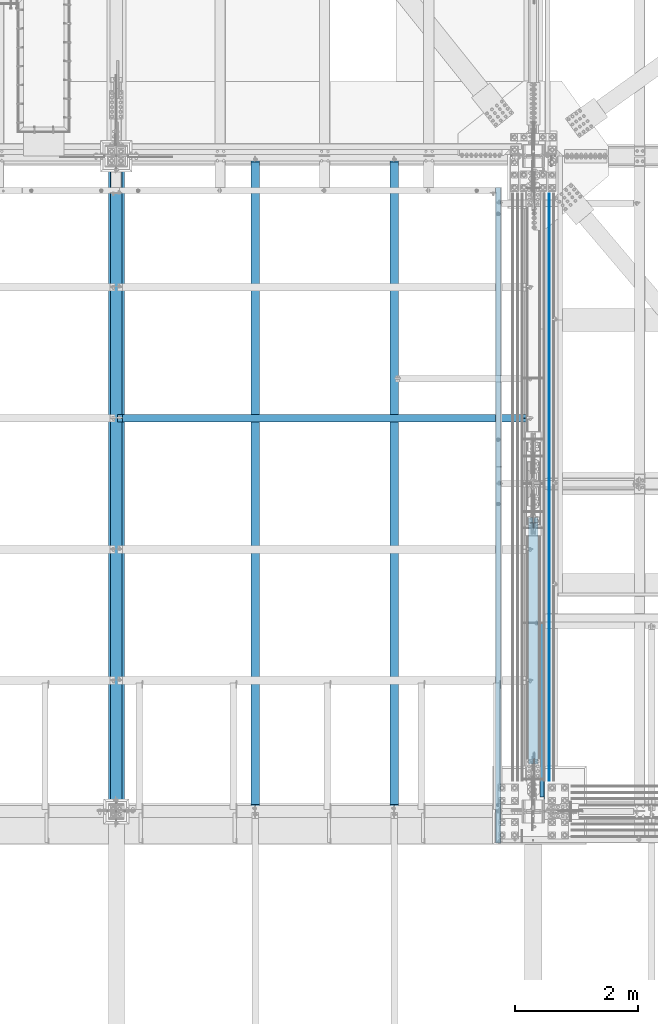
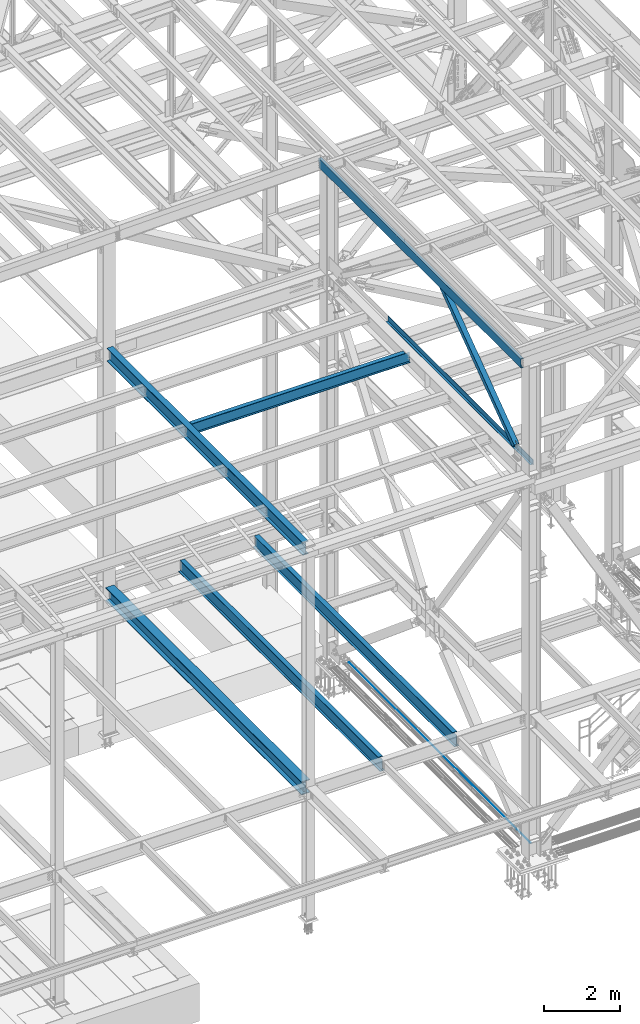
# One storey, part 1795 of 3843: 8 beams, 1 member, 9 elements without a shape of their own.
"""IFC2X3 building model written with IfcOpenShell, lengths in millimetres."""

from ifc_helpers import new_model, si_unit, frame, origin_with_axes, place, context, subcontext, project, spatial, faceted_brep, material, type_object, element, aggregate, save


model = new_model("IFC2X3")

# Units and contexts
model_context = context("Model", 3, precision=1e-05, world=origin_with_axes())
body_context = subcontext(model_context, "Body", "Model", "MODEL_VIEW")
ifc_project = project(units=[si_unit("LENGTHUNIT", "METRE", prefix="MILLI"), si_unit("AREAUNIT", "SQUARE_METRE"), si_unit("VOLUMEUNIT", "CUBIC_METRE"), si_unit("MASSUNIT", "GRAM", prefix="KILO"), si_unit("TIMEUNIT", "SECOND"), si_unit("PLANEANGLEUNIT", "RADIAN"), si_unit("SOLIDANGLEUNIT", "STERADIAN"), si_unit("THERMODYNAMICTEMPERATUREUNIT", "DEGREE_CELSIUS"), si_unit("LUMINOUSINTENSITYUNIT", "LUMEN")], contexts=[model_context])

# Site, building, storey
site_placement = place(None, origin_with_axes())
site = spatial("IfcSite", under=ifc_project, at=site_placement, CompositionType="ELEMENT")
building_placement = place(site_placement, origin_with_axes())
building = spatial("IfcBuilding", under=site, at=building_placement, Name="Undefined", CompositionType="ELEMENT")
storey_placement = place(building_placement, origin_with_axes())
storey = spatial("IfcBuildingStorey", under=building, at=storey_placement, Name="Undefined", CompositionType="ELEMENT", Elevation=0.0)

# Assembly, beam
assembly_1_placement = place(storey_placement, origin_with_axes())
assembly_1 = element("IfcElementAssembly", 1, at=assembly_1_placement, inside=storey, Name="CHANNEL", AssemblyPlace="NOTDEFINED", PredefinedType="RIGID_FRAME")
ifc_material_1 = material(Name="STEEL/A572-50")
beam_type_1 = type_object("IfcBeamType", Name="C12X20.7", PredefinedType="NOTDEFINED")
beam_1_placement = place(assembly_1_placement, frame((76444.5150555766, 14490.7, 46420.6519803864), z_axis=(-0.0211520980073474, 0.0, 0.999776269347241), x_axis=(0.0, 1.0, 0.0)))
beam_1 = element("IfcBeam", 2, at=beam_1_placement, type_object=beam_type_1, material=ifc_material_1, Name="CHANNEL", ObjectType="C12X20.7", context=body_context, shape_type="Brep", body=[
    faceted_brep([(0.0, 38.0999999999985, -152.400000000001), (0.0, 38.0999999999985, 152.400000000001), (10617.1999999989, 38.1000000003551, 152.399999999732), (10617.1999999989, 38.1000000000495, -152.399999999776), (0.0, -38.0999999999985, 152.400000000001), (10617.1999999989, -38.1000000000786, 152.39999999979), (0.0, -38.0999999999985, 146.047460000002), (10617.1999999989, -38.1000000000786, 146.047459999805), (0.0, 30.1624999999985, 134.6749275), (10617.1999999989, 30.1625000002969, 134.674927499764), (0.0, 30.1624999999985, -134.6749275), (10617.1999999989, 30.1625000000058, -134.6749274998), (0.0, -38.0999999999985, -146.047460000002), (10617.1999999989, -38.1000000003696, -146.047459999725), (0.0, -38.0999999999985, -152.400000000001), (10617.1999999989, -38.1000000003842, -152.399999999718)], [[[0, 1, 2, 3]], [[1, 4, 5, 2]], [[4, 6, 7, 5]], [[6, 8, 9, 7]], [[8, 10, 11, 9]], [[10, 12, 13, 11]], [[12, 14, 15, 13]], [[14, 0, 3, 15]], [[5, 7, 9, 11, 13, 15, 3, 2]], [[14, 12, 10, 8, 6, 4, 1, 0]]]),
])
aggregate(assembly_1, [beam_1])

assembly_2_placement = place(storey_placement, origin_with_axes())
assembly_2 = element("IfcElementAssembly", 3, at=assembly_2_placement, inside=storey, Name="REBAR", AssemblyPlace="NOTDEFINED", PredefinedType="RIGID_FRAME")
ifc_material_2 = material(Name="STEEL/A706-60")
beam_type_2 = type_object("IfcBeamType", Name="#10 REBAR", PredefinedType="NOTDEFINED")
beam_2_placement = place(assembly_2_placement, frame((77266.8, 25006.3, 30157.7375), z_axis=(0.0, 0.0, 1.0), x_axis=(0.0, -1.0, 0.0)))
beam_2 = element("IfcBeam", 4, at=beam_2_placement, type_object=beam_type_2, material=ifc_material_2, Name="REBAR", ObjectType="#10 REBAR", context=body_context, shape_type="Brep", body=[
    faceted_brep([(0.0, -7.9375, 0.0), (0.0, -5.61266007566883, -5.61266007566883), (9512.38738280515, -5.61266007566883, -5.61266007566883), (9512.38738280515, -7.9375, 0.0), (0.0, 0.0, -7.9375), (9512.38738280515, 0.0, -7.9375), (0.0, 5.61266007566883, -5.61266007566883), (9512.38738280515, 5.61266007566883, -5.61266007566883), (0.0, 7.9375, 0.0), (9512.38738280515, 7.9375, 0.0), (0.0, 5.61266007566883, 5.61266007566883), (9512.38738280515, 5.61266007566883, 5.61266007566883), (0.0, 0.0, 7.9375), (9512.38738280515, 0.0, 7.9375), (0.0, -5.61266007566883, 5.61266007566883), (9512.38738280515, -5.61266007566883, 5.61266007566883)], [[[0, 1, 2, 3]], [[1, 4, 5, 2]], [[4, 6, 7, 5]], [[6, 8, 9, 7]], [[8, 10, 11, 9]], [[10, 12, 13, 11]], [[12, 14, 15, 13]], [[14, 0, 3, 15]], [[5, 7, 9, 11, 13, 15, 3, 2]], [[14, 12, 10, 8, 6, 4, 1, 0]]]),
])
aggregate(assembly_2, [beam_2])

assembly_3_placement = place(storey_placement, origin_with_axes())
assembly_3 = element("IfcElementAssembly", 5, at=assembly_3_placement, inside=storey, Name="BENT_PLATE", AssemblyPlace="NOTDEFINED", PredefinedType="RIGID_FRAME")
ifc_material_3 = material(Name="STEEL/A36")
beam_type_3 = type_object("IfcBeamType", PredefinedType="NOTDEFINED")
beam_3_placement = place(assembly_3_placement, frame((77117.5749999987, 19003.9625, 42471.975), z_axis=(0.0, -1.0, 0.0), x_axis=(1.0, 0.0, 0.0)))
beam_3 = element("IfcBeam", 6, at=beam_3_placement, type_object=beam_type_3, material=ifc_material_3, Name="BENT_PLATE", context=body_context, shape_type="Brep", body=[
    faceted_brep([(9.52499997243285, -3.17500000000291, 3153.56874999937), (9.52499997243285, 3.17499999999563, 3153.56874999937), (0.0, 3.17500000000291, 3153.56875000306), (0.0, -3.17500000000291, 3153.56875000306), (9.5249999724183, -3.17500000000291, 3471.06874999936), (9.5249999724183, 3.17499999999563, 3471.06874999936), (0.0, -3.17500000000291, 3471.06874999937), (0.0, 3.17500000000291, 3471.06874999937), (73.0250000012456, -3.17500000001746, 3810.0), (73.0250000012456, -3.17500000001746, -3810.0), (73.0250000012456, 161.924999998715, -3810.0), (73.0250000012456, 161.924999998715, 3810.0), (66.6750000011525, -3.17500000001746, 3772.68489935418), (66.6750000012398, 3.17499999998836, 3772.68489935418), (0.0, 3.17500000000291, 3772.68489935418), (0.0, -3.17500000000291, 3772.68489935418), (66.675000001138, -3.17500000001746, 3810.0), (66.6750000012398, 3.17499999998836, 3810.0), (66.6750000012398, 161.924999998715, 3810.0), (66.6750000012398, 101.124999999993, 3810.0), (66.6750000012398, 3.17499999998836, -3810.0), (66.6750000012398, 161.924999998715, -3810.0), (0.0, -3.17500000000291, -3810.0), (0.0, 3.17500000000291, -3810.0)], [[[0, 1, 2, 3]], [[4, 5, 1, 0]], [[6, 7, 5, 4]], [[8, 9, 10, 11]], [[12, 13, 14, 15]], [[16, 17, 13, 12]], [[8, 11, 18, 19, 17, 16]], [[20, 13, 17, 19, 18, 21]], [[11, 10, 21, 18]], [[9, 22, 23, 20, 21, 10]], [[23, 22, 3, 2]], [[14, 13, 20, 23, 2, 1, 5, 7]], [[15, 14, 7, 6]], [[3, 22, 9, 8, 16, 12, 15, 6, 4, 0]]]),
])
aggregate(assembly_3, [beam_3])

# Assembly, member
assembly_4_placement = place(storey_placement, origin_with_axes())
assembly_4 = element("IfcElementAssembly", 7, at=assembly_4_placement, inside=storey, AssemblyPlace="NOTDEFINED", PredefinedType="RIGID_FRAME")
ifc_material_4 = material()
member_type = type_object("IfcMemberType", Name="HSS6X6X3/8", PredefinedType="NOTDEFINED")
member_placement = place(assembly_4_placement, frame((77012.8, 14998.7, 42197.3375), z_axis=(1.0, 0.0, 0.0), x_axis=(0.0, 0.80816825191759, 0.588951675939942)))
member = element("IfcMember", 8, at=member_placement, type_object=member_type, material=ifc_material_4, ObjectType="HSS6X6X3/8", context=body_context, shape_type="Brep", body=[
    faceted_brep([(1006.47933077956, -76.1999999982509, 20.6374999999971), (1006.47933077959, -66.6749999982421, 20.6374999999971), (1106.49183077885, -66.6749999980639, 20.6374999999971), (1106.49183077881, -76.1999999980653, 20.6374999999971), (1109.52938052324, -66.6749999980566, 20.0332937893108), (1109.52938052321, -76.1999999980653, 20.0332937893108), (1112.10449085452, -66.6749999980566, 18.3126600756659), (1112.10449085449, -76.1999999980653, 18.3126600756659), (1113.82512456816, -66.674999998053, 15.7375497444009), (1113.82512456813, -76.199999998058, 15.7375497444009), (1106.49183077881, -76.1999999980653, 4.76249999999709), (1106.49183077885, -66.6749999980639, 4.76249999999709), (1006.47933077959, -66.6749999982421, 4.76249999999709), (1006.47933077956, -76.1999999982509, 4.76249999999709), (1109.52938052321, -76.1999999980653, 5.36670621068333), (1109.52938052324, -66.6749999980566, 5.36670621068333), (1112.10449085449, -76.1999999980653, 7.08733992432826), (1112.10449085452, -66.6749999980566, 7.08733992432826), (1113.82512456813, -76.199999998058, 9.66245025559328), (1113.82512456816, -66.674999998053, 9.66245025559328), (1114.42933077882, -76.199999998058, 12.6999999999971), (1114.42933077885, -66.6749999980493, 12.6999999999971), (1006.47933077993, 66.6750000018656, 20.6374999999971), (1006.47933077996, 76.2000000018743, 20.6374999999971), (1106.49183077931, 76.2000000020525, 20.6374999999971), (1106.49183077928, 66.6750000020511, 20.6374999999971), (1109.52938052371, 76.2000000020562, 20.0332937893108), (1109.52938052368, 66.6750000020511, 20.0332937893108), (1112.10449085499, 76.2000000020635, 18.3126600756659), (1112.10449085495, 66.6750000020584, 18.3126600756659), (1113.82512456863, 76.2000000020671, 15.7375497444009), (1113.8251245686, 66.6750000020584, 15.7375497444009), (1106.49183077928, 66.6750000020511, 4.76249999999709), (1106.49183077931, 76.2000000020525, 4.76249999999709), (1006.47933077996, 76.2000000018743, 4.76249999999709), (1006.47933077993, 66.6750000018656, 4.76249999999709), (1109.52938052368, 66.6750000020511, 5.36670621068333), (1109.52938052371, 76.2000000020562, 5.36670621068333), (1112.10449085495, 66.6750000020584, 7.08733992432826), (1112.10449085499, 76.2000000020635, 7.08733992432826), (1113.8251245686, 66.6750000020584, 9.66245025559328), (1113.82512456863, 76.2000000020671, 9.66245025559328), (1114.42933077929, 66.6750000020656, 12.6999999999971), (1114.42933077933, 76.2000000020671, 12.6999999999971), (1006.47933077959, -66.6749999982421, 66.6750000000029), (1006.47933077993, 66.6750000018656, 66.6750000000029), (5842.45196320163, 66.675000010564, 66.6750000000029), (5842.45196320129, -66.6749999895401, 66.6750000000029), (1006.47933077996, 76.2000000018743, 76.1999999999971), (5842.45196320165, 76.2000000105763, 76.1999999999971), (5842.45196320165, 76.2000000105763, 7.9374999889551), (5742.43946319877, 76.2000000103981, 7.9374999889551), (5739.40191345436, 76.2000000103908, 7.33329377826885), (5736.82680312308, 76.2000000103835, 5.61266006462392), (5735.10616940944, 76.2000000103835, 3.0375497333589), (5734.50196319875, 76.2000000103799, -1.10449036583304e-08), (5735.10616940944, 76.2000000103835, -3.03754975544871), (5736.82680312308, 76.2000000103835, -5.61266008671373), (5739.40191345436, 76.2000000103908, -7.33329380035866), (5742.43946319877, 76.2000000103981, -7.9375000110449), (5842.45196320165, 76.2000000105763, -7.9375000110449), (5842.45196320165, 76.2000000105763, -76.1999999999971), (1006.47933077996, 76.2000000018743, -76.1999999999971), (5842.45196320163, 66.675000010564, 7.9374999889551), (5742.43946319875, 66.6750000103893, 7.9374999889551), (5739.40191345434, 66.6750000103821, 7.33329377826885), (5736.82680312307, 66.6750000103784, 5.61266006462392), (5735.10616940942, 66.6750000103711, 3.0375497333589), (5734.50196319873, 66.6750000103748, -1.10449036583304e-08), (5735.10616940942, 66.6750000103711, -3.03754975544871), (5736.82680312307, 66.6750000103784, -5.61266008671373), (5739.40191345434, 66.6750000103821, -7.33329380035866), (5742.43946319875, 66.6750000103893, -7.9375000110449), (5842.45196320163, 66.675000010564, -7.9375000110449), (1006.47933077993, 66.6750000018656, -66.6750000000029), (1006.47933077959, -66.6749999982421, -66.6750000000029), (5842.45196320129, -66.6749999895401, -66.6750000000029), (5842.45196320163, 66.675000010564, -66.6750000000029), (5739.40191345409, -76.1999999897307, 7.33329377826885), (5739.40191345411, -66.6749999897183, 7.33329377826885), (5742.43946319851, -66.6749999897183, 7.9374999889551), (5742.43946319849, -76.1999999897344, 7.9374999889551), (5736.82680312281, -76.199999989738, 5.61266006462392), (5736.82680312283, -66.6749999897256, 5.61266006462392), (5735.10616940917, -76.199999989738, 3.0375497333589), (5735.10616940918, -66.6749999897329, 3.0375497333589), (5734.50196319847, -76.1999999897416, -1.10449036583304e-08), (5734.50196319848, -66.6749999897293, -1.10449036583304e-08), (5735.10616940917, -76.199999989738, -3.03754975544871), (5735.10616940918, -66.6749999897329, -3.03754975544871), (5736.82680312281, -76.199999989738, -5.61266008671373), (5736.82680312283, -66.6749999897256, -5.61266008671373), (5739.40191345409, -76.1999999897307, -7.33329380035866), (5739.40191345411, -66.6749999897183, -7.33329380035866), (5742.43946319849, -76.1999999897344, -7.9375000110449), (5742.43946319851, -66.6749999897183, -7.9375000110449), (5842.45196320127, -76.1999999895488, -7.9375000110449), (5842.45196320129, -66.6749999895401, -7.9375000110449), (5842.45196320127, -76.1999999895488, -76.1999999999971), (1006.47933077956, -76.1999999982509, -76.1999999999971), (5842.45196320129, -66.6749999895401, 7.9374999889551), (5842.45196320127, -76.1999999895488, 7.9374999889551), (5842.45196320127, -76.1999999895488, 76.1999999999971), (1006.47933077956, -76.1999999982509, 76.1999999999971)], [[[0, 1, 2, 3]], [[3, 2, 4, 5]], [[5, 4, 6, 7]], [[7, 6, 8, 9]], [[10, 11, 12, 13]], [[14, 15, 11, 10]], [[16, 17, 15, 14]], [[18, 19, 17, 16]], [[20, 21, 19, 18]], [[9, 8, 21, 20]], [[22, 23, 24, 25]], [[25, 24, 26, 27]], [[27, 26, 28, 29]], [[29, 28, 30, 31]], [[32, 33, 34, 35]], [[36, 37, 33, 32]], [[38, 39, 37, 36]], [[40, 41, 39, 38]], [[42, 43, 41, 40]], [[31, 30, 43, 42]], [[44, 45, 46, 47]], [[28, 26, 24, 23, 48, 49, 50, 51, 52, 53, 54, 55, 56, 57, 58, 59, 60, 61, 62, 34, 33, 37, 39, 41, 43, 30]], [[63, 64, 51, 50]], [[65, 52, 51, 64]], [[66, 53, 52, 65]], [[67, 54, 53, 66]], [[68, 55, 54, 67]], [[69, 56, 55, 68]], [[70, 57, 56, 69]], [[71, 58, 57, 70]], [[72, 59, 58, 71]], [[73, 60, 59, 72]], [[74, 75, 76, 77]], [[78, 79, 80, 81]], [[82, 83, 79, 78]], [[84, 85, 83, 82]], [[86, 87, 85, 84]], [[88, 89, 87, 86]], [[90, 91, 89, 88]], [[92, 93, 91, 90]], [[94, 95, 93, 92]], [[96, 97, 95, 94]], [[98, 61, 60, 73, 77, 76, 97, 96]], [[99, 62, 61, 98]], [[75, 74, 35, 34, 62, 99, 13, 12]], [[6, 4, 2, 1, 44, 47, 100, 80, 79, 83, 85, 87, 89, 91, 93, 95, 97, 76, 75, 12, 11, 15, 17, 19, 21, 8]], [[101, 81, 80, 100]], [[47, 46, 63, 50, 49, 102, 101, 100]], [[48, 103, 102, 49]], [[16, 14, 10, 13, 99, 98, 96, 94, 92, 90, 88, 86, 84, 82, 78, 81, 101, 102, 103, 0, 3, 5, 7, 9, 20, 18]], [[103, 48, 23, 22, 45, 44, 1, 0]], [[38, 36, 32, 35, 74, 77, 73, 72, 71, 70, 69, 68, 67, 66, 65, 64, 63, 46, 45, 22, 25, 27, 29, 31, 42, 40]]]),
])
aggregate(assembly_4, [member])

# Assembly, beam
assembly_5_placement = place(storey_placement, origin_with_axes())
assembly_5 = element("IfcElementAssembly", 9, at=assembly_5_placement, inside=storey, Name="BEAM", AssemblyPlace="NOTDEFINED", PredefinedType="RIGID_FRAME")
ifc_material_5 = material(Name="STEEL/A992")
beam_type_4 = type_object("IfcBeamType", Name="W14X26", PredefinedType="NOTDEFINED")
beam_4_placement = place(assembly_5_placement, frame((70256.4, 21369.02, 42292.5875), z_axis=(0.0, 0.0, 1.0), x_axis=(1.0, 0.0, 0.0)))
beam_4 = element("IfcBeam", 10, at=beam_4_placement, type_object=beam_type_4, material=ifc_material_5, Name="BEAM", ObjectType="W14X26", context=body_context, shape_type="Brep", body=[
    faceted_brep([(6588.12499999999, -63.5, 176.212500000001), (6588.12499999999, -63.5, 165.099999999999), (6588.12499999999, -3.17499999999927, 165.099999999999), (6588.12499999999, -3.17499999999927, 136.524999809262), (6588.12499999999, 3.17499999999927, 136.524999809262), (6588.12499999999, 3.17499999999927, 165.099999999999), (6588.12499999999, 63.5, 165.099999999999), (6588.12499999999, 63.5, 176.212500000001), (6589.09172992257, -3.17499999999927, 131.664920291216), (6589.09172992257, 3.17499999999927, 131.664920291216), (6591.84474382305, -3.17499999999927, 127.544743823062), (6591.84474382305, 3.17499999999927, 127.544743823062), (6595.96492029121, -3.17499999999927, 124.791729922588), (6595.96492029121, 3.17499999999927, 124.791729922588), (6600.82499980925, -3.17499999999927, 123.824999999997), (6600.82499980925, 3.17499999999927, 123.824999999997), (6737.34999999999, -3.17499999999927, 123.824999999997), (6737.34999999999, 3.17499999999927, 123.824999999997), (103.18750152587, -63.5, 176.212500000001), (103.18750152587, 63.5, 176.212500000001), (103.18750152587, 63.5, 165.099999999999), (103.18750152587, 3.17499999999927, 165.099999999999), (103.18750152587, 3.17499999999927, 153.987499809264), (103.18750152587, -3.17499999999927, 153.987499809264), (103.18750152587, -3.17499999999927, 165.099999999999), (103.18750152587, -63.5, 165.099999999999), (102.220771603286, 3.17499999999927, 149.127420291217), (102.220771603286, -3.17499999999927, 149.127420291217), (99.4677577028051, 3.17499999999927, 145.007243823064), (99.4677577028051, -3.17499999999927, 145.007243823064), (95.3475812346442, 3.17499999999927, 142.25422992259), (95.3475812346442, -3.17499999999927, 142.25422992259), (90.487501716605, 3.17499999999927, 141.287499999999), (90.487501716605, -3.17499999999927, 141.287499999999), (18.2562499999913, 3.17499999999927, 141.287499999999), (18.2562499999913, -3.17499999999927, 141.287499999999), (18.2562499999913, 3.17499999999927, 125.412499999999), (18.2562499999913, 3.17499999999927, -105.1875), (18.2562499999913, 3.17499999999927, -165.099999999999), (18.2562499999913, 63.5, -165.099999999999), (18.2562499999913, 63.5, -176.212500000001), (18.2562499999913, -63.5, -176.212500000001), (18.2562499999913, -63.5, -165.099999999999), (18.2562499999913, -3.17499999999927, -165.099999999999), (6737.34999999999, 3.17499999999927, -165.099999999999), (6737.34999999999, 63.5, -165.099999999999), (6737.34999999999, 63.5, -176.212500000001), (6737.34999999999, -63.5, -176.212500000001), (6737.34999999999, -63.5, -165.099999999999), (6737.34999999999, -3.17499999999927, -165.099999999999), (6737.34999999999, 3.17499999999927, -105.1875)], [[[0, 1, 2, 3, 4, 5, 6, 7]], [[8, 9, 4, 3]], [[10, 11, 9, 8]], [[12, 13, 11, 10]], [[14, 15, 13, 12]], [[16, 17, 15, 14]], [[18, 19, 20, 21, 22, 23, 24, 25]], [[23, 22, 26, 27]], [[27, 26, 28, 29]], [[29, 28, 30, 31]], [[31, 30, 32, 33]], [[33, 32, 34, 35]], [[36, 37, 38, 39, 40, 41, 42, 43, 35, 34]], [[39, 38, 44, 45]], [[40, 39, 45, 46]], [[41, 40, 46, 47]], [[42, 41, 47, 48]], [[43, 42, 48, 49]], [[12, 10, 8, 3, 2, 24, 23, 27, 29, 31, 33, 35, 43, 49, 16, 14]], [[25, 24, 2, 1]], [[18, 25, 1, 0]], [[19, 18, 0, 7]], [[20, 19, 7, 6]], [[21, 20, 6, 5]], [[50, 44, 38, 37, 36, 34, 32, 30, 28, 26, 22, 21, 5, 4, 9, 11, 13, 15, 17]], [[49, 48, 47, 46, 45, 44, 50, 17, 16]]]),
])
aggregate(assembly_5, [beam_4])

assembly_6_placement = place(storey_placement, origin_with_axes())
assembly_6 = element("IfcElementAssembly", 11, at=assembly_6_placement, inside=storey, Name="BEAM", AssemblyPlace="NOTDEFINED", PredefinedType="RIGID_FRAME")
beam_type_5 = type_object("IfcBeamType", Name="W16X31", PredefinedType="NOTDEFINED")
beam_5_placement = place(assembly_6_placement, frame((74760.534374, 14998.7, 34609.0875), z_axis=(0.0, 0.0, 1.0), x_axis=(0.0, 1.0, 0.0)))
beam_5 = element("IfcBeam", 12, at=beam_5_placement, type_object=beam_type_5, material=ifc_material_5, Name="BEAM", ObjectType="W16X31", context=body_context, shape_type="Brep", body=[
    faceted_brep([(100.806249528396, -3.17500000000291, 169.86250000001), (100.806249528396, 3.17500000000291, 169.86250000001), (18.2562500000004, 3.17500000000291, 169.86250000001), (18.2562500000004, -3.17500000000291, 169.86250000001), (105.666329046442, -3.17500000000291, 170.829229922601), (105.666329046442, 3.17500000000291, 170.829229922601), (109.786505514596, -3.17500000000291, 173.582243823075), (109.786505514596, 3.17500000000291, 173.582243823075), (112.539519415073, -3.17500000000291, 177.702420291229), (112.539519415073, 3.17500000000291, 177.702420291229), (113.506249337661, -3.17500000000291, 182.562499809275), (113.506249337661, 3.17500000000291, 182.562499809275), (113.506249337661, -69.8500000000058, 201.612500000003), (113.506249337661, 69.8500000000058, 201.612500000003), (113.506249337661, 69.8500000000058, 190.5), (113.506249337661, 3.17500000000291, 190.5), (113.506249337661, -3.17500000000291, 190.5), (113.506249337661, -69.8500000000058, 190.5), (18.2562500000004, -3.17500000000291, -190.5), (18.2562500000004, -69.8500000000058, -190.5), (10600.53125, -69.8500000000058, -190.5), (10600.53125, -3.17500000000291, -190.5), (18.2562500000004, -69.8500000000058, -201.612500000003), (10600.53125, -69.8500000000058, -201.612500000003), (18.2562500000004, 69.8500000000058, -201.612500000003), (10600.53125, 69.8500000000058, -201.612500000003), (18.2562500000004, 69.8500000000058, -190.5), (10600.53125, 69.8500000000058, -190.5), (18.2562500000004, 3.17500000000291, -190.5), (10600.53125, 3.17500000000291, -190.5), (10600.53125, 3.17500000000291, -143.287499999999), (10600.53125, 3.17500000000291, 163.512499999997), (10600.53125, 3.17500000000291, 176.212500000009), (10600.53125, -3.17500000000291, 176.212500000009), (10537.0312504716, 3.17500000000291, 176.212500000009), (10537.0312504716, -3.17500000000291, 176.212500000009), (10532.1711709536, 3.17500000000291, 177.1792299226), (10532.1711709536, -3.17500000000291, 177.1792299226), (10528.0509944854, 3.17500000000291, 179.932243823074), (10528.0509944854, -3.17500000000291, 179.932243823074), (10525.2979805849, 3.17500000000291, 184.052420291227), (10525.2979805849, -3.17500000000291, 184.052420291227), (10524.3312506624, 3.17500000000291, 188.912499809274), (10524.3312506624, -3.17500000000291, 188.912499809274), (10524.3312506624, -69.8500000000058, 201.612500000003), (10524.3312506624, -69.8500000000058, 190.5), (10524.3312506624, -3.17500000000291, 190.5), (10524.3312506624, 3.17500000000291, 190.5), (10524.3312506624, 69.8500000000058, 190.5), (10524.3312506624, 69.8500000000058, 201.612500000003), (18.2562500000004, 3.17500000000291, 163.512499999997), (18.2562500000004, 3.17500000000291, -143.287499999999)], [[[0, 1, 2, 3]], [[4, 5, 1, 0]], [[6, 7, 5, 4]], [[8, 9, 7, 6]], [[10, 11, 9, 8]], [[12, 13, 14, 15, 11, 10, 16, 17]], [[18, 19, 20, 21]], [[19, 22, 23, 20]], [[22, 24, 25, 23]], [[24, 26, 27, 25]], [[26, 28, 29, 27]], [[21, 20, 23, 25, 27, 29, 30, 31, 32, 33]], [[33, 32, 34, 35]], [[35, 34, 36, 37]], [[37, 36, 38, 39]], [[39, 38, 40, 41]], [[41, 40, 42, 43]], [[44, 45, 46, 43, 42, 47, 48, 49]], [[45, 44, 12, 17]], [[46, 45, 17, 16]], [[8, 6, 4, 0, 3, 18, 21, 33, 35, 37, 39, 41, 43, 46, 16, 10]], [[50, 51, 28, 26, 24, 22, 19, 18, 3, 2]], [[47, 42, 40, 38, 36, 34, 32, 31, 30, 29, 28, 51, 50, 2, 1, 5, 7, 9, 11, 15]], [[48, 47, 15, 14]], [[49, 48, 14, 13]], [[44, 49, 13, 12]]]),
])
aggregate(assembly_6, [beam_5])

assembly_7_placement = place(storey_placement, origin_with_axes())
assembly_7 = element("IfcElementAssembly", 13, at=assembly_7_placement, inside=storey, Name="BEAM", AssemblyPlace="NOTDEFINED", PredefinedType="RIGID_FRAME")
beam_6_placement = place(assembly_7_placement, frame((72508.467187, 14998.7, 34609.0875), z_axis=(0.0, 0.0, 1.0), x_axis=(0.0, 1.0, 0.0)))
beam_6 = element("IfcBeam", 14, at=beam_6_placement, type_object=beam_type_5, material=ifc_material_5, Name="BEAM", ObjectType="W16X31", context=body_context, shape_type="Brep", body=[
    faceted_brep([(100.806249528396, -3.17500000000291, 169.86250000001), (100.806249528396, 3.17500000000291, 169.86250000001), (18.2562500000004, 3.17500000000291, 169.86250000001), (18.2562500000004, -3.17500000000291, 169.86250000001), (105.666329046442, -3.17500000000291, 170.829229922601), (105.666329046442, 3.17500000000291, 170.829229922601), (109.786505514596, -3.17500000000291, 173.582243823075), (109.786505514596, 3.17500000000291, 173.582243823075), (112.539519415073, -3.17500000000291, 177.702420291229), (112.539519415073, 3.17500000000291, 177.702420291229), (113.506249337661, -3.17500000000291, 182.562499809275), (113.506249337661, 3.17500000000291, 182.562499809275), (113.506249337661, -69.8500000000058, 201.612500000003), (113.506249337661, 69.8500000000058, 201.612500000003), (113.506249337661, 69.8500000000058, 190.5), (113.506249337661, 3.17500000000291, 190.5), (113.506249337661, -3.17500000000291, 190.5), (113.506249337661, -69.8500000000058, 190.5), (18.2562500000004, -3.17500000000291, -190.5), (18.2562500000004, -69.8500000000058, -190.5), (10600.53125, -69.8500000000058, -190.5), (10600.53125, -3.17500000000291, -190.5), (18.2562500000004, -69.8500000000058, -201.612500000003), (10600.53125, -69.8500000000058, -201.612500000003), (18.2562500000004, 69.8500000000058, -201.612500000003), (10600.53125, 69.8500000000058, -201.612500000003), (18.2562500000004, 69.8500000000058, -190.5), (10600.53125, 69.8500000000058, -190.5), (18.2562500000004, 3.17500000000291, -190.5), (10600.53125, 3.17500000000291, -190.5), (10600.53125, 3.17500000000291, -143.287499999999), (10600.53125, 3.17500000000291, 163.512499999997), (10600.53125, 3.17500000000291, 176.212500000009), (10600.53125, -3.17500000000291, 176.212500000009), (10537.0312504716, 3.17500000000291, 176.212500000009), (10537.0312504716, -3.17500000000291, 176.212500000009), (10532.1711709536, 3.17500000000291, 177.1792299226), (10532.1711709536, -3.17500000000291, 177.1792299226), (10528.0509944854, 3.17500000000291, 179.932243823074), (10528.0509944854, -3.17500000000291, 179.932243823074), (10525.2979805849, 3.17500000000291, 184.052420291227), (10525.2979805849, -3.17500000000291, 184.052420291227), (10524.3312506624, 3.17500000000291, 188.912499809274), (10524.3312506624, -3.17500000000291, 188.912499809274), (10524.3312506624, -69.8500000000058, 201.612500000003), (10524.3312506624, -69.8500000000058, 190.5), (10524.3312506624, -3.17500000000291, 190.5), (10524.3312506624, 3.17500000000291, 190.5), (10524.3312506624, 69.8500000000058, 190.5), (10524.3312506624, 69.8500000000058, 201.612500000003), (18.2562500000004, 3.17500000000291, 163.512499999997), (18.2562500000004, 3.17500000000291, -143.287499999999)], [[[0, 1, 2, 3]], [[4, 5, 1, 0]], [[6, 7, 5, 4]], [[8, 9, 7, 6]], [[10, 11, 9, 8]], [[12, 13, 14, 15, 11, 10, 16, 17]], [[18, 19, 20, 21]], [[19, 22, 23, 20]], [[22, 24, 25, 23]], [[24, 26, 27, 25]], [[26, 28, 29, 27]], [[21, 20, 23, 25, 27, 29, 30, 31, 32, 33]], [[33, 32, 34, 35]], [[35, 34, 36, 37]], [[37, 36, 38, 39]], [[39, 38, 40, 41]], [[41, 40, 42, 43]], [[44, 45, 46, 43, 42, 47, 48, 49]], [[45, 44, 12, 17]], [[46, 45, 17, 16]], [[8, 6, 4, 0, 3, 18, 21, 33, 35, 37, 39, 41, 43, 46, 16, 10]], [[50, 51, 28, 26, 24, 22, 19, 18, 3, 2]], [[47, 42, 40, 38, 36, 34, 32, 31, 30, 29, 28, 51, 50, 2, 1, 5, 7, 9, 11, 15]], [[48, 47, 15, 14]], [[49, 48, 14, 13]], [[44, 49, 13, 12]]]),
])
aggregate(assembly_7, [beam_6])

assembly_8_placement = place(storey_placement, origin_with_axes())
assembly_8 = element("IfcElementAssembly", 15, at=assembly_8_placement, inside=storey, Name="BEAM", AssemblyPlace="NOTDEFINED", PredefinedType="RIGID_FRAME")
beam_type_6 = type_object("IfcBeamType", Name="W16X57", PredefinedType="NOTDEFINED")
beam_7_placement = place(assembly_8_placement, frame((70256.4, 14998.7, 42260.8375), z_axis=(0.0, 0.0, 1.0), x_axis=(0.0, 1.0, 0.0)))
beam_7 = element("IfcBeam", 16, at=beam_7_placement, type_object=beam_type_6, material=ifc_material_5, Name="BEAM", ObjectType="W16X57", context=body_context, shape_type="Brep", body=[
    faceted_brep([(142.874999999998, -90.4875000000029, -207.962500000001), (142.874999999998, 90.4875000000029, -207.962500000001), (10426.7, 90.4875000000029, -207.962500000001), (10426.7, -90.4875000000029, -207.962500000001), (142.874999999998, -90.4875000000029, -190.5), (142.874999999998, -5.55624999999418, -190.5), (142.874999999998, -5.55624999999418, 190.5), (142.874999999998, -90.4875000000029, 190.5), (142.874999999998, -90.4875000000029, 207.962500000001), (142.874999999998, 90.4875000000029, 207.962500000001), (142.874999999998, 90.4875000000029, 190.5), (142.874999999998, 5.55624999999418, 190.5), (142.874999999998, 5.55624999999418, -190.5), (142.874999999998, 90.4875000000029, -190.5), (10426.7, -90.4875000000029, -190.5), (10426.7, -5.55624999999418, -190.5), (10426.7, -5.55624999999418, 190.5), (10426.7, -90.4875000000029, 190.5), (10426.7, -90.4875000000029, 207.962500000001), (10426.7, 90.4875000000029, 207.962500000001), (10426.7, 90.4875000000029, 190.5), (10426.7, 5.55624999999418, 190.5), (10426.7, 5.55624999999418, -190.5), (10426.7, 90.4875000000029, -190.5)], [[[0, 1, 2, 3]], [[0, 4, 5, 6, 7, 8, 9, 10, 11, 12, 13, 1]], [[5, 4, 14, 15]], [[6, 5, 15, 16]], [[7, 6, 16, 17]], [[8, 7, 17, 18]], [[9, 8, 18, 19]], [[10, 9, 19, 20]], [[11, 10, 20, 21]], [[12, 11, 21, 22]], [[13, 12, 22, 23]], [[1, 13, 23, 2]], [[22, 21, 20, 19, 18, 17, 16, 15, 14, 3, 2, 23]], [[4, 0, 3, 14]]]),
])
aggregate(assembly_8, [beam_7])

assembly_9_placement = place(storey_placement, origin_with_axes())
assembly_9 = element("IfcElementAssembly", 17, at=assembly_9_placement, inside=storey, Name="BEAM", AssemblyPlace="NOTDEFINED", PredefinedType="RIGID_FRAME")
beam_type_7 = type_object("IfcBeamType", Name="W16X77", PredefinedType="NOTDEFINED")
beam_8_placement = place(assembly_9_placement, frame((70256.4, 14998.7, 34601.15), z_axis=(0.0, 0.0, 1.0), x_axis=(0.0, 1.0, 0.0)))
beam_8 = element("IfcBeam", 18, at=beam_8_placement, type_object=beam_type_7, material=ifc_material_5, Name="BEAM", ObjectType="W16X77", context=body_context, shape_type="Brep", body=[
    faceted_brep([(10426.7, 5.55624999999418, -190.5), (10426.7, 130.175000000003, -190.5), (150.69859824655, 130.175000000003, -190.5), (150.69859824655, 5.55624999999418, -190.5), (10426.7, -130.175000000003, -209.550000000003), (10426.7, -130.175000000003, -190.5), (150.69859824655, -130.175000000003, -190.5), (139.699999999999, -130.175000000003, -209.550000000003), (10426.7, 130.175000000003, -209.550000000003), (139.699999999999, 130.175000000003, -209.550000000003), (10426.7, 5.55624999999418, 190.5), (10426.7, 130.175000000003, 190.5), (10426.7, 130.175000000003, 209.550000000003), (10426.7, -130.175000000003, 209.550000000003), (10426.7, -130.175000000003, 190.5), (10426.7, -5.55624999999418, 190.5), (10426.7, -5.55624999999418, -190.5), (139.699999999999, 5.55624999999418, 190.102999496463), (139.699999999999, -5.55624999999418, 190.102999496463), (139.699999999999, -5.55624999999418, 190.5), (139.699999999999, 5.55624999999418, 190.5), (165.10000152588, 5.55624999999418, 190.102999496463), (165.10000152588, -5.55624999999418, 190.102999496463), (211.693448365435, 5.55624999999418, 180.79025946014), (211.693448365435, -5.55624999999418, 180.79025946014), (216.566753565228, 5.55624999999418, 178.180215038927), (216.566753565228, -5.55624999999418, 178.180215038927), (219.169596365356, 5.55624999999418, 173.303059637583), (219.169596365356, -5.55624999999418, 173.303059637583), (218.62519450505, 5.55624999999418, 167.801690529304), (218.62519450505, -5.55624999999418, 167.801690529304), (215.116932817931, 5.55624999999418, 163.52927489108), (215.116932817931, -5.55624999999418, 163.52927489108), (209.826589017679, 5.55624999999418, 161.925000000003), (209.826589017679, -5.55624999999418, 161.925000000003), (142.874999999987, 5.55624999999418, 161.925000000003), (142.874999999987, -5.55624999999418, 161.925000000003), (142.874999999987, 5.55624999999418, -161.925000000003), (142.874999999987, -5.55624999999418, -161.925000000003), (208.583589242771, 5.55624999999418, -161.925000000003), (208.583589242771, -5.55624999999418, -161.925000000003), (213.873933026549, 5.55624999999418, -163.529274880071), (213.873933026549, -5.55624999999418, -163.529274880071), (217.382194714966, 5.55624999999418, -167.801690492699), (217.382194714966, -5.55624999999418, -167.801690492699), (217.926596602014, 5.55624999999418, -173.303059579281), (217.926596602014, -5.55624999999418, -173.303059579281), (215.323753846324, 5.55624999999418, -178.180214982844), (215.323753846324, -5.55624999999418, -178.180214982844), (210.450448687674, 5.55624999999418, -180.790259440721), (210.450448687674, -5.55624999999418, -180.790259440721), (163.857004272462, 5.55624999999418, -190.102999496463), (163.857004272462, -5.55624999999418, -190.102999496463), (150.927799780187, 5.55624999999418, -190.102999496463), (150.927799780187, -5.55624999999418, -190.102999496463), (150.69859824655, -5.55624999999418, -190.5), (139.699999999999, 130.175000000003, 190.5), (150.698581967608, 130.175000000003, 209.550000000003), (150.698581967608, -130.175000000003, 209.550000000003), (139.699999999999, -130.175000000003, 190.5)], [[[0, 1, 2, 3]], [[4, 5, 6, 7]], [[8, 4, 7, 9]], [[1, 8, 9, 2]], [[0, 10, 11, 12, 13, 14, 15, 16, 5, 4, 8, 1]], [[17, 18, 19, 20]], [[21, 22, 18, 17]], [[22, 21, 23, 24]], [[24, 23, 25, 26]], [[26, 25, 27, 28]], [[28, 27, 29, 30]], [[30, 29, 31, 32]], [[32, 31, 33, 34]], [[34, 33, 35, 36]], [[36, 35, 37, 38]], [[39, 40, 38, 37]], [[40, 39, 41, 42]], [[42, 41, 43, 44]], [[44, 43, 45, 46]], [[46, 45, 47, 48]], [[48, 47, 49, 50]], [[50, 49, 51, 52]], [[52, 51, 53, 54]], [[16, 15, 19, 18, 22, 24, 26, 28, 30, 32, 34, 36, 38, 40, 42, 44, 46, 48, 50, 52, 54, 55]], [[5, 16, 55, 6]], [[54, 53, 3, 2, 9, 7, 6, 55]], [[51, 49, 47, 45, 43, 41, 39, 37, 35, 33, 31, 29, 27, 25, 23, 21, 17, 20, 10, 0, 3, 53]], [[11, 10, 20, 56]], [[12, 11, 56, 57]], [[13, 12, 57, 58]], [[14, 13, 58, 59]], [[15, 14, 59, 19]], [[58, 57, 56, 20, 19, 59]]]),
])
aggregate(assembly_9, [beam_8])

save(model, "model.ifc")
